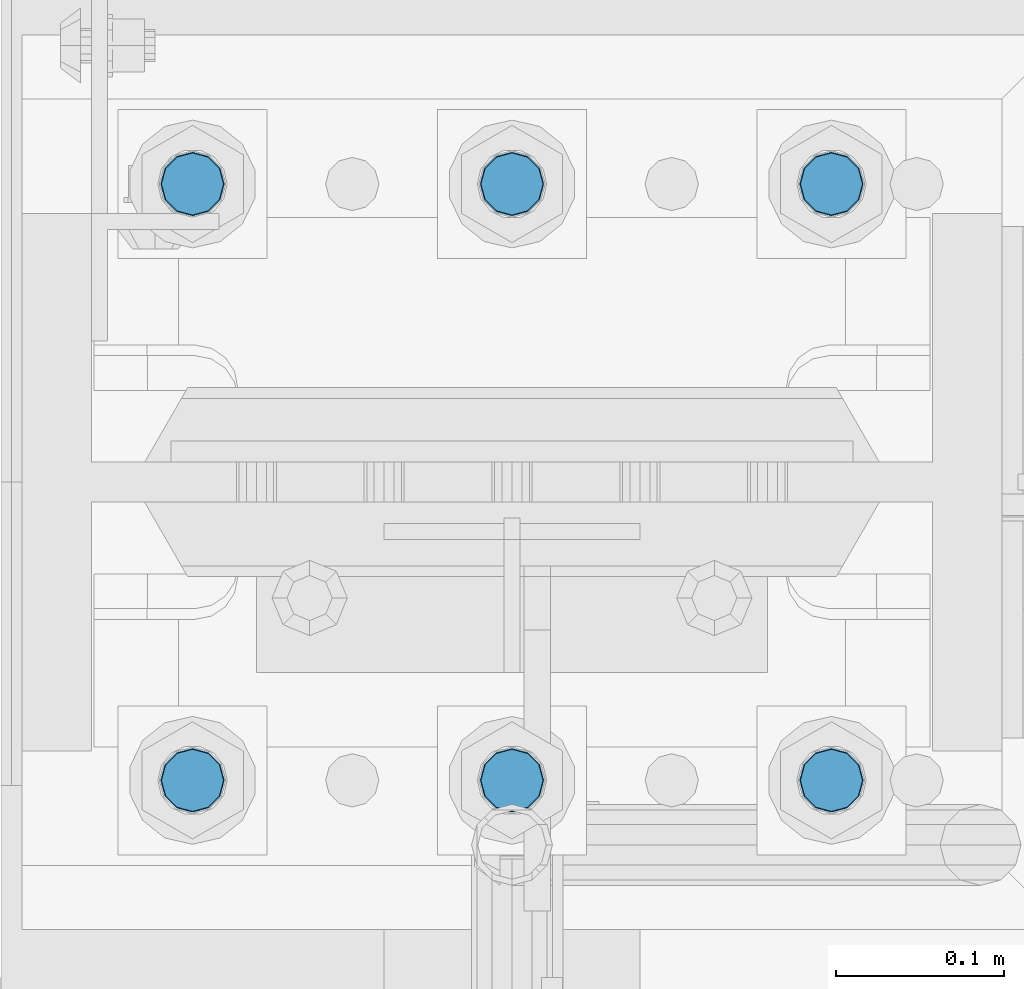
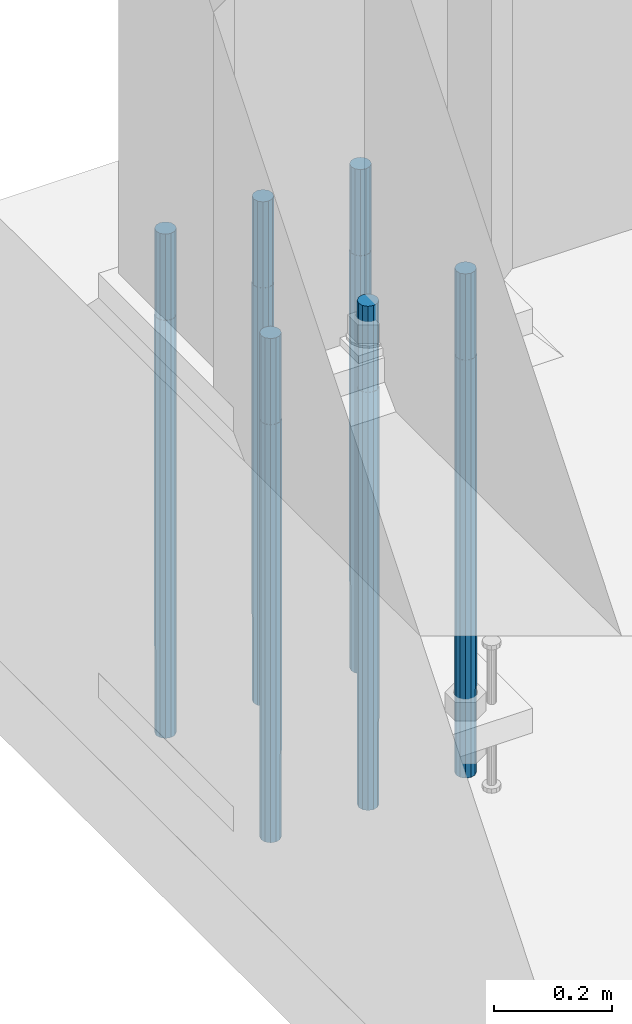
# One storey, part 750 of 1876: 6 columns, 1 element without a shape of its own.
"""IFC2X3 building model written with IfcOpenShell, lengths in millimetres."""

from ifc_helpers import new_model, si_unit, frame, origin_with_axes, place, context, subcontext, project, spatial, faceted_brep, material, type_object, element, aggregate, save


model = new_model("IFC2X3")

# Units and contexts
model_context = context("Model", 3, precision=1e-05, world=origin_with_axes())
body_context = subcontext(model_context, "Body", "Model", "MODEL_VIEW")
ifc_project = project(units=[si_unit("LENGTHUNIT", "METRE", prefix="MILLI"), si_unit("AREAUNIT", "SQUARE_METRE"), si_unit("VOLUMEUNIT", "CUBIC_METRE"), si_unit("MASSUNIT", "GRAM", prefix="KILO"), si_unit("TIMEUNIT", "SECOND"), si_unit("PLANEANGLEUNIT", "RADIAN"), si_unit("SOLIDANGLEUNIT", "STERADIAN"), si_unit("THERMODYNAMICTEMPERATUREUNIT", "DEGREE_CELSIUS"), si_unit("LUMINOUSINTENSITYUNIT", "LUMEN")], contexts=[model_context])

# Site, building, storey
site_placement = place(None, origin_with_axes())
site = spatial("IfcSite", under=ifc_project, at=site_placement, CompositionType="ELEMENT")
building_placement = place(site_placement, origin_with_axes())
building = spatial("IfcBuilding", under=site, at=building_placement, Name="Undefined", CompositionType="ELEMENT")
storey_placement = place(building_placement, origin_with_axes())
storey = spatial("IfcBuildingStorey", under=building, at=storey_placement, Name="Undefined", CompositionType="ELEMENT", Elevation=0.0)

# Assembly, columns
assembly_placement = place(storey_placement, origin_with_axes())
assembly = element("IfcElementAssembly", 1, at=assembly_placement, inside=storey, Name="TEMPLATE", AssemblyPlace="NOTDEFINED", PredefinedType="RIGID_FRAME")
ifc_material = material(Name="STEEL/F1554-GR.105")
column_type = type_object("IfcColumnType", PredefinedType="NOTDEFINED")
column_1_placement = place(assembly_placement, frame((190.5, 13538.2, 0.0), z_axis=(1.0, 0.0, 0.0), x_axis=(0.0, 0.0, -1.0)))
column_1 = element("IfcColumn", 2, at=column_1_placement, type_object=column_type, material=ifc_material, Name="ANCHOR_BOLTS", context=body_context, shape_type="Brep", body=[
    faceted_brep([(-177.8, -16.0214699700118, 9.25), (-177.8, -9.25, 16.0214699700121), (-177.8, 0.0, 18.5), (-177.8, 9.25, 16.0214699700121), (-177.8, 16.0214699700118, 9.25), (-177.8, 18.5, 0.0), (-177.8, 16.0214699700118, -9.25), (-177.8, 9.25, -16.0214699700121), (-177.8, 0.0, -18.5), (-177.8, -9.25, -16.0214699700121), (-177.8, -16.0214699700118, -9.25), (-177.8, -18.5, 0.0), (0.0, 18.5, 0.0), (0.0, 16.0214699700118, -9.25), (0.0, 9.25, -16.0214699700121), (0.0, 0.0, -18.5), (0.0, -9.25, -16.0214699700121), (0.0, -16.0214699700118, -9.25), (0.0, -18.5, 0.0), (0.0, -16.0214699700118, 9.25), (0.0, -9.25, 16.0214699700121), (0.0, 0.0, 18.5), (0.0, 9.25, 16.0214699700121), (0.0, 16.0214699700118, 9.25), (0.0, -16.4977839420935, 9.52500000000146), (0.0, -9.52500000000009, 16.4977839420935), (0.0, 0.0, 19.0499999999993), (0.0, 9.52500000000009, 16.4977839420935), (0.0, 16.4977839420935, 9.52500000000146), (-9.09494701772928e-13, 19.05, -1.81898940354586e-12), (0.0, 16.4977839420935, -9.52500000000146), (0.0, 9.52500000000009, -16.4977839420935), (0.0, 0.0, -19.05), (0.0, -9.52500000000009, -16.4977839420935), (0.0, -16.4977839420935, -9.52500000000146), (0.0, -19.0500000000002, 0.0), (685.799999999999, -19.05, 0.0), (685.799999999999, -16.4977839420936, 9.52500000000146), (685.799999999999, -9.52499999999998, 16.4977839420935), (685.799999999999, 0.0, 19.0499999999993), (685.799999999999, 9.52499999999998, 16.4977839420935), (685.799999999999, 16.4977839420936, 9.52500000000146), (685.799999999999, 19.05, 0.0), (685.799999999999, 16.4977839420936, -9.52500000000146), (685.799999999999, 9.52500000000003, -16.4977839420935), (685.799999999999, 0.0, -19.0499999999993), (685.799999999999, -9.52499999999998, -16.4977839420935), (685.799999999999, -16.4977839420936, -9.52500000000146), (685.8, -9.25, 16.0214699700121), (685.8, 0.0, 18.5), (685.8, 9.25, 16.0214699700121), (685.8, 16.0214699700118, 9.25), (685.8, 18.5, 0.0), (685.8, 16.0214699700118, -9.25), (685.8, 9.25, -16.0214699700121), (685.8, 0.0, -18.5), (685.8, -9.25, -16.0214699700121), (685.8, -16.0214699700118, -9.25), (685.8, -18.5, 0.0), (685.8, -16.0214699700118, 9.25), (863.6, -9.25, -16.0214699700121), (863.6, 0.0, -18.5), (863.6, 9.25, -16.0214699700121), (863.6, 16.0214699700118, -9.25), (863.6, 18.5, 0.0), (863.6, 16.0214699700118, 9.25), (863.6, 9.25, 16.0214699700121), (863.6, 0.0, 18.5), (863.6, -9.25, 16.0214699700121), (863.6, -16.0214699700118, 9.25), (863.6, -18.5, 0.0), (863.6, -16.0214699700118, -9.25)], [[[0, 1, 2, 3, 4, 5, 6, 7, 8, 9, 10, 11]], [[6, 5, 12, 13]], [[7, 6, 13, 14]], [[8, 7, 14, 15]], [[9, 8, 15, 16]], [[10, 9, 16, 17]], [[11, 10, 17, 18]], [[0, 11, 18, 19]], [[1, 0, 19, 20]], [[2, 1, 20, 21]], [[3, 2, 21, 22]], [[4, 3, 22, 23]], [[5, 4, 23, 12]], [[24, 25, 26, 27, 28, 29, 30, 31, 32, 33, 34, 35], [22, 21, 20, 19, 18, 17, 16, 15, 14, 13, 12, 23]], [[24, 35, 36, 37]], [[25, 24, 37, 38]], [[26, 25, 38, 39]], [[27, 26, 39, 40]], [[28, 27, 40, 41]], [[29, 28, 41, 42]], [[30, 29, 42, 43]], [[31, 30, 43, 44]], [[32, 31, 44, 45]], [[33, 32, 45, 46]], [[34, 33, 46, 47]], [[35, 34, 47, 36]], [[46, 45, 44, 43, 42, 41, 40, 39, 38, 37, 36, 47], [48, 49, 50, 51, 52, 53, 54, 55, 56, 57, 58, 59]], [[60, 61, 62, 63, 64, 65, 66, 67, 68, 69, 70, 71]], [[68, 67, 49, 48]], [[69, 68, 48, 59]], [[70, 69, 59, 58]], [[71, 70, 58, 57]], [[60, 71, 57, 56]], [[61, 60, 56, 55]], [[62, 61, 55, 54]], [[63, 62, 54, 53]], [[64, 63, 53, 52]], [[65, 64, 52, 51]], [[66, 65, 51, 50]], [[67, 66, 50, 49]]]),
])
column_2_placement = place(assembly_placement, frame((190.5, 13893.8, 0.0), z_axis=(-1.0, 0.0, 0.0), x_axis=(0.0, 0.0, -1.0)))
column_2 = element("IfcColumn", 3, at=column_2_placement, type_object=column_type, material=ifc_material, Name="ANCHOR_BOLTS", context=body_context, shape_type="Brep", body=[
    faceted_brep([(-177.8, -16.0214699700118, 9.25), (-177.8, -9.25, 16.0214699700121), (-177.8, 0.0, 18.5), (-177.8, 9.25, 16.0214699700121), (-177.8, 16.0214699700118, 9.25), (-177.8, 18.5, 0.0), (-177.8, 16.0214699700118, -9.25), (-177.8, 9.25, -16.0214699700121), (-177.8, 0.0, -18.5), (-177.8, -9.25, -16.0214699700121), (-177.8, -16.0214699700118, -9.25), (-177.8, -18.5, 0.0), (0.0, 18.5, 0.0), (0.0, 16.0214699700118, -9.25), (0.0, 9.25, -16.0214699700121), (0.0, 0.0, -18.5), (0.0, -9.25, -16.0214699700121), (0.0, -16.0214699700118, -9.25), (0.0, -18.5, 0.0), (0.0, -16.0214699700118, 9.25), (0.0, -9.25, 16.0214699700121), (0.0, 0.0, 18.5), (0.0, 9.25, 16.0214699700121), (0.0, 16.0214699700118, 9.25), (0.0, -16.4977839420935, 9.52500000000146), (0.0, -9.52500000000009, 16.4977839420935), (0.0, 0.0, 19.0499999999993), (0.0, 9.52500000000009, 16.4977839420935), (0.0, 16.4977839420935, 9.52500000000146), (-9.09494701772928e-13, 19.05, -1.81898940354586e-12), (0.0, 16.4977839420935, -9.52500000000146), (0.0, 9.52500000000009, -16.4977839420935), (0.0, 0.0, -19.05), (0.0, -9.52500000000009, -16.4977839420935), (0.0, -16.4977839420935, -9.52500000000146), (0.0, -19.0500000000002, 0.0), (685.799999999999, -19.05, 0.0), (685.799999999999, -16.4977839420936, 9.52500000000146), (685.799999999999, -9.52499999999998, 16.4977839420935), (685.799999999999, 0.0, 19.0499999999993), (685.799999999999, 9.52499999999998, 16.4977839420935), (685.799999999999, 16.4977839420936, 9.52500000000146), (685.799999999999, 19.05, 0.0), (685.799999999999, 16.4977839420936, -9.52500000000146), (685.799999999999, 9.52500000000003, -16.4977839420935), (685.799999999999, 0.0, -19.0499999999993), (685.799999999999, -9.52499999999998, -16.4977839420935), (685.799999999999, -16.4977839420936, -9.52500000000146), (685.8, -9.25, 16.0214699700121), (685.8, 0.0, 18.5), (685.8, 9.25, 16.0214699700121), (685.8, 16.0214699700118, 9.25), (685.8, 18.5, 0.0), (685.8, 16.0214699700118, -9.25), (685.8, 9.25, -16.0214699700121), (685.8, 0.0, -18.5), (685.8, -9.25, -16.0214699700121), (685.8, -16.0214699700118, -9.25), (685.8, -18.5, 0.0), (685.8, -16.0214699700118, 9.25), (863.6, -9.25, -16.0214699700121), (863.6, 0.0, -18.5), (863.6, 9.25, -16.0214699700121), (863.6, 16.0214699700118, -9.25), (863.6, 18.5, 0.0), (863.6, 16.0214699700118, 9.25), (863.6, 9.25, 16.0214699700121), (863.6, 0.0, 18.5), (863.6, -9.25, 16.0214699700121), (863.6, -16.0214699700118, 9.25), (863.6, -18.5, 0.0), (863.6, -16.0214699700118, -9.25)], [[[0, 1, 2, 3, 4, 5, 6, 7, 8, 9, 10, 11]], [[6, 5, 12, 13]], [[7, 6, 13, 14]], [[8, 7, 14, 15]], [[9, 8, 15, 16]], [[10, 9, 16, 17]], [[11, 10, 17, 18]], [[0, 11, 18, 19]], [[1, 0, 19, 20]], [[2, 1, 20, 21]], [[3, 2, 21, 22]], [[4, 3, 22, 23]], [[5, 4, 23, 12]], [[24, 25, 26, 27, 28, 29, 30, 31, 32, 33, 34, 35], [22, 21, 20, 19, 18, 17, 16, 15, 14, 13, 12, 23]], [[24, 35, 36, 37]], [[25, 24, 37, 38]], [[26, 25, 38, 39]], [[27, 26, 39, 40]], [[28, 27, 40, 41]], [[29, 28, 41, 42]], [[30, 29, 42, 43]], [[31, 30, 43, 44]], [[32, 31, 44, 45]], [[33, 32, 45, 46]], [[34, 33, 46, 47]], [[35, 34, 47, 36]], [[46, 45, 44, 43, 42, 41, 40, 39, 38, 37, 36, 47], [48, 49, 50, 51, 52, 53, 54, 55, 56, 57, 58, 59]], [[60, 61, 62, 63, 64, 65, 66, 67, 68, 69, 70, 71]], [[68, 67, 49, 48]], [[69, 68, 48, 59]], [[70, 69, 59, 58]], [[71, 70, 58, 57]], [[60, 71, 57, 56]], [[61, 60, 56, 55]], [[62, 61, 55, 54]], [[63, 62, 54, 53]], [[64, 63, 53, 52]], [[65, 64, 52, 51]], [[66, 65, 51, 50]], [[67, 66, 50, 49]]]),
])
column_3_placement = place(assembly_placement, frame((-2.8421709430404e-14, 13538.2, 0.0), z_axis=(1.0, 0.0, 0.0), x_axis=(0.0, 0.0, -1.0)))
column_3 = element("IfcColumn", 4, at=column_3_placement, type_object=column_type, material=ifc_material, Name="ANCHOR_BOLTS", context=body_context, shape_type="Brep", body=[
    faceted_brep([(-177.8, -16.0214699700118, 9.25), (-177.8, -9.25, 16.0214699700121), (-177.8, 0.0, 18.5), (-177.8, 9.25, 16.0214699700121), (-177.8, 16.0214699700118, 9.25), (-177.8, 18.5, 0.0), (-177.8, 16.0214699700118, -9.25), (-177.8, 9.25, -16.0214699700121), (-177.8, 0.0, -18.5), (-177.8, -9.25, -16.0214699700121), (-177.8, -16.0214699700118, -9.25), (-177.8, -18.5, 0.0), (0.0, 18.5, 0.0), (0.0, 16.0214699700118, -9.25), (0.0, 9.25, -16.0214699700121), (0.0, 0.0, -18.5), (0.0, -9.25, -16.0214699700121), (0.0, -16.0214699700118, -9.25), (0.0, -18.5, 0.0), (0.0, -16.0214699700118, 9.25), (0.0, -9.25, 16.0214699700121), (0.0, 0.0, 18.5), (0.0, 9.25, 16.0214699700121), (0.0, 16.0214699700118, 9.25), (0.0, -16.4977839420935, 9.52500000000146), (0.0, -9.52500000000009, 16.4977839420935), (0.0, 0.0, 19.0499999999993), (0.0, 9.52500000000009, 16.4977839420935), (0.0, 16.4977839420935, 9.52500000000146), (-9.09494701772928e-13, 19.05, -1.81898940354586e-12), (0.0, 16.4977839420935, -9.52500000000146), (0.0, 9.52500000000009, -16.4977839420935), (0.0, 0.0, -19.05), (0.0, -9.52500000000009, -16.4977839420935), (0.0, -16.4977839420935, -9.52500000000146), (0.0, -19.0500000000002, 0.0), (685.799999999999, -19.05, 0.0), (685.799999999999, -16.4977839420936, 9.52500000000146), (685.799999999999, -9.52499999999998, 16.4977839420935), (685.799999999999, 0.0, 19.0499999999993), (685.799999999999, 9.52499999999998, 16.4977839420935), (685.799999999999, 16.4977839420936, 9.52500000000146), (685.799999999999, 19.05, 0.0), (685.799999999999, 16.4977839420936, -9.52500000000146), (685.799999999999, 9.52500000000003, -16.4977839420935), (685.799999999999, 0.0, -19.0499999999993), (685.799999999999, -9.52499999999998, -16.4977839420935), (685.799999999999, -16.4977839420936, -9.52500000000146), (685.8, -9.25, 16.0214699700121), (685.8, 0.0, 18.5), (685.8, 9.25, 16.0214699700121), (685.8, 16.0214699700118, 9.25), (685.8, 18.5, 0.0), (685.8, 16.0214699700118, -9.25), (685.8, 9.25, -16.0214699700121), (685.8, 0.0, -18.5), (685.8, -9.25, -16.0214699700121), (685.8, -16.0214699700118, -9.25), (685.8, -18.5, 0.0), (685.8, -16.0214699700118, 9.25), (863.6, -9.25, -16.0214699700121), (863.6, 0.0, -18.5), (863.6, 9.25, -16.0214699700121), (863.6, 16.0214699700118, -9.25), (863.6, 18.5, 0.0), (863.6, 16.0214699700118, 9.25), (863.6, 9.25, 16.0214699700121), (863.6, 0.0, 18.5), (863.6, -9.25, 16.0214699700121), (863.6, -16.0214699700118, 9.25), (863.6, -18.5, 0.0), (863.6, -16.0214699700118, -9.25)], [[[0, 1, 2, 3, 4, 5, 6, 7, 8, 9, 10, 11]], [[6, 5, 12, 13]], [[7, 6, 13, 14]], [[8, 7, 14, 15]], [[9, 8, 15, 16]], [[10, 9, 16, 17]], [[11, 10, 17, 18]], [[0, 11, 18, 19]], [[1, 0, 19, 20]], [[2, 1, 20, 21]], [[3, 2, 21, 22]], [[4, 3, 22, 23]], [[5, 4, 23, 12]], [[24, 25, 26, 27, 28, 29, 30, 31, 32, 33, 34, 35], [22, 21, 20, 19, 18, 17, 16, 15, 14, 13, 12, 23]], [[24, 35, 36, 37]], [[25, 24, 37, 38]], [[26, 25, 38, 39]], [[27, 26, 39, 40]], [[28, 27, 40, 41]], [[29, 28, 41, 42]], [[30, 29, 42, 43]], [[31, 30, 43, 44]], [[32, 31, 44, 45]], [[33, 32, 45, 46]], [[34, 33, 46, 47]], [[35, 34, 47, 36]], [[46, 45, 44, 43, 42, 41, 40, 39, 38, 37, 36, 47], [48, 49, 50, 51, 52, 53, 54, 55, 56, 57, 58, 59]], [[60, 61, 62, 63, 64, 65, 66, 67, 68, 69, 70, 71]], [[68, 67, 49, 48]], [[69, 68, 48, 59]], [[70, 69, 59, 58]], [[71, 70, 58, 57]], [[60, 71, 57, 56]], [[61, 60, 56, 55]], [[62, 61, 55, 54]], [[63, 62, 54, 53]], [[64, 63, 53, 52]], [[65, 64, 52, 51]], [[66, 65, 51, 50]], [[67, 66, 50, 49]]]),
])
column_4_placement = place(assembly_placement, frame((-2.8421709430404e-14, 13893.8, 0.0), z_axis=(-1.0, 0.0, 0.0), x_axis=(0.0, 0.0, -1.0)))
column_4 = element("IfcColumn", 5, at=column_4_placement, type_object=column_type, material=ifc_material, Name="ANCHOR_BOLTS", context=body_context, shape_type="Brep", body=[
    faceted_brep([(-177.8, -16.0214699700118, 9.25), (-177.8, -9.25, 16.0214699700121), (-177.8, 0.0, 18.5), (-177.8, 9.25, 16.0214699700121), (-177.8, 16.0214699700118, 9.25), (-177.8, 18.5, 0.0), (-177.8, 16.0214699700118, -9.25), (-177.8, 9.25, -16.0214699700121), (-177.8, 0.0, -18.5), (-177.8, -9.25, -16.0214699700121), (-177.8, -16.0214699700118, -9.25), (-177.8, -18.5, 0.0), (0.0, 18.5, 0.0), (0.0, 16.0214699700118, -9.25), (0.0, 9.25, -16.0214699700121), (0.0, 0.0, -18.5), (0.0, -9.25, -16.0214699700121), (0.0, -16.0214699700118, -9.25), (0.0, -18.5, 0.0), (0.0, -16.0214699700118, 9.25), (0.0, -9.25, 16.0214699700121), (0.0, 0.0, 18.5), (0.0, 9.25, 16.0214699700121), (0.0, 16.0214699700118, 9.25), (0.0, -16.4977839420935, 9.52500000000146), (0.0, -9.52500000000009, 16.4977839420935), (0.0, 0.0, 19.0499999999993), (0.0, 9.52500000000009, 16.4977839420935), (0.0, 16.4977839420935, 9.52500000000146), (-9.09494701772928e-13, 19.05, -1.81898940354586e-12), (0.0, 16.4977839420935, -9.52500000000146), (0.0, 9.52500000000009, -16.4977839420935), (0.0, 0.0, -19.05), (0.0, -9.52500000000009, -16.4977839420935), (0.0, -16.4977839420935, -9.52500000000146), (0.0, -19.0500000000002, 0.0), (685.799999999999, -19.05, 0.0), (685.799999999999, -16.4977839420936, 9.52500000000146), (685.799999999999, -9.52499999999998, 16.4977839420935), (685.799999999999, 0.0, 19.0499999999993), (685.799999999999, 9.52499999999998, 16.4977839420935), (685.799999999999, 16.4977839420936, 9.52500000000146), (685.799999999999, 19.05, 0.0), (685.799999999999, 16.4977839420936, -9.52500000000146), (685.799999999999, 9.52500000000003, -16.4977839420935), (685.799999999999, 0.0, -19.0499999999993), (685.799999999999, -9.52499999999998, -16.4977839420935), (685.799999999999, -16.4977839420936, -9.52500000000146), (685.8, -9.25, 16.0214699700121), (685.8, 0.0, 18.5), (685.8, 9.25, 16.0214699700121), (685.8, 16.0214699700118, 9.25), (685.8, 18.5, 0.0), (685.8, 16.0214699700118, -9.25), (685.8, 9.25, -16.0214699700121), (685.8, 0.0, -18.5), (685.8, -9.25, -16.0214699700121), (685.8, -16.0214699700118, -9.25), (685.8, -18.5, 0.0), (685.8, -16.0214699700118, 9.25), (863.6, -9.25, -16.0214699700121), (863.6, 0.0, -18.5), (863.6, 9.25, -16.0214699700121), (863.6, 16.0214699700118, -9.25), (863.6, 18.5, 0.0), (863.6, 16.0214699700118, 9.25), (863.6, 9.25, 16.0214699700121), (863.6, 0.0, 18.5), (863.6, -9.25, 16.0214699700121), (863.6, -16.0214699700118, 9.25), (863.6, -18.5, 0.0), (863.6, -16.0214699700118, -9.25)], [[[0, 1, 2, 3, 4, 5, 6, 7, 8, 9, 10, 11]], [[6, 5, 12, 13]], [[7, 6, 13, 14]], [[8, 7, 14, 15]], [[9, 8, 15, 16]], [[10, 9, 16, 17]], [[11, 10, 17, 18]], [[0, 11, 18, 19]], [[1, 0, 19, 20]], [[2, 1, 20, 21]], [[3, 2, 21, 22]], [[4, 3, 22, 23]], [[5, 4, 23, 12]], [[24, 25, 26, 27, 28, 29, 30, 31, 32, 33, 34, 35], [22, 21, 20, 19, 18, 17, 16, 15, 14, 13, 12, 23]], [[24, 35, 36, 37]], [[25, 24, 37, 38]], [[26, 25, 38, 39]], [[27, 26, 39, 40]], [[28, 27, 40, 41]], [[29, 28, 41, 42]], [[30, 29, 42, 43]], [[31, 30, 43, 44]], [[32, 31, 44, 45]], [[33, 32, 45, 46]], [[34, 33, 46, 47]], [[35, 34, 47, 36]], [[46, 45, 44, 43, 42, 41, 40, 39, 38, 37, 36, 47], [48, 49, 50, 51, 52, 53, 54, 55, 56, 57, 58, 59]], [[60, 61, 62, 63, 64, 65, 66, 67, 68, 69, 70, 71]], [[68, 67, 49, 48]], [[69, 68, 48, 59]], [[70, 69, 59, 58]], [[71, 70, 58, 57]], [[60, 71, 57, 56]], [[61, 60, 56, 55]], [[62, 61, 55, 54]], [[63, 62, 54, 53]], [[64, 63, 53, 52]], [[65, 64, 52, 51]], [[66, 65, 51, 50]], [[67, 66, 50, 49]]]),
])
column_5_placement = place(assembly_placement, frame((-190.5, 13538.2, 0.0), z_axis=(1.0, 0.0, 0.0), x_axis=(0.0, 0.0, -1.0)))
column_5 = element("IfcColumn", 6, at=column_5_placement, type_object=column_type, material=ifc_material, Name="ANCHOR_BOLTS", context=body_context, shape_type="Brep", body=[
    faceted_brep([(-177.8, -16.0214699700118, 9.25), (-177.8, -9.25, 16.0214699700121), (-177.8, 0.0, 18.5), (-177.8, 9.25, 16.0214699700121), (-177.8, 16.0214699700118, 9.25), (-177.8, 18.5, 0.0), (-177.8, 16.0214699700118, -9.25), (-177.8, 9.25, -16.0214699700121), (-177.8, 0.0, -18.5), (-177.8, -9.25, -16.0214699700121), (-177.8, -16.0214699700118, -9.25), (-177.8, -18.5, 0.0), (0.0, 18.5, 0.0), (0.0, 16.0214699700118, -9.25), (0.0, 9.25, -16.0214699700121), (0.0, 0.0, -18.5), (0.0, -9.25, -16.0214699700121), (0.0, -16.0214699700118, -9.25), (0.0, -18.5, 0.0), (0.0, -16.0214699700118, 9.25), (0.0, -9.25, 16.0214699700121), (0.0, 0.0, 18.5), (0.0, 9.25, 16.0214699700121), (0.0, 16.0214699700118, 9.25), (0.0, -16.4977839420935, 9.52500000000146), (0.0, -9.52500000000009, 16.4977839420935), (0.0, 0.0, 19.0499999999993), (0.0, 9.52500000000009, 16.4977839420935), (0.0, 16.4977839420935, 9.52500000000146), (-9.09494701772928e-13, 19.05, -1.81898940354586e-12), (0.0, 16.4977839420935, -9.52500000000146), (0.0, 9.52500000000009, -16.4977839420935), (0.0, 0.0, -19.05), (0.0, -9.52500000000009, -16.4977839420935), (0.0, -16.4977839420935, -9.52500000000146), (0.0, -19.0500000000002, 0.0), (685.799999999999, -19.05, 0.0), (685.799999999999, -16.4977839420936, 9.52500000000146), (685.799999999999, -9.52499999999998, 16.4977839420935), (685.799999999999, 0.0, 19.0499999999993), (685.799999999999, 9.52499999999998, 16.4977839420935), (685.799999999999, 16.4977839420936, 9.52500000000146), (685.799999999999, 19.05, 0.0), (685.799999999999, 16.4977839420936, -9.52500000000146), (685.799999999999, 9.52500000000003, -16.4977839420935), (685.799999999999, 0.0, -19.0499999999993), (685.799999999999, -9.52499999999998, -16.4977839420935), (685.799999999999, -16.4977839420936, -9.52500000000146), (685.8, -9.25, 16.0214699700121), (685.8, 0.0, 18.5), (685.8, 9.25, 16.0214699700121), (685.8, 16.0214699700118, 9.25), (685.8, 18.5, 0.0), (685.8, 16.0214699700118, -9.25), (685.8, 9.25, -16.0214699700121), (685.8, 0.0, -18.5), (685.8, -9.25, -16.0214699700121), (685.8, -16.0214699700118, -9.25), (685.8, -18.5, 0.0), (685.8, -16.0214699700118, 9.25), (863.6, -9.25, -16.0214699700121), (863.6, 0.0, -18.5), (863.6, 9.25, -16.0214699700121), (863.6, 16.0214699700118, -9.25), (863.6, 18.5, 0.0), (863.6, 16.0214699700118, 9.25), (863.6, 9.25, 16.0214699700121), (863.6, 0.0, 18.5), (863.6, -9.25, 16.0214699700121), (863.6, -16.0214699700118, 9.25), (863.6, -18.5, 0.0), (863.6, -16.0214699700118, -9.25)], [[[0, 1, 2, 3, 4, 5, 6, 7, 8, 9, 10, 11]], [[6, 5, 12, 13]], [[7, 6, 13, 14]], [[8, 7, 14, 15]], [[9, 8, 15, 16]], [[10, 9, 16, 17]], [[11, 10, 17, 18]], [[0, 11, 18, 19]], [[1, 0, 19, 20]], [[2, 1, 20, 21]], [[3, 2, 21, 22]], [[4, 3, 22, 23]], [[5, 4, 23, 12]], [[24, 25, 26, 27, 28, 29, 30, 31, 32, 33, 34, 35], [22, 21, 20, 19, 18, 17, 16, 15, 14, 13, 12, 23]], [[24, 35, 36, 37]], [[25, 24, 37, 38]], [[26, 25, 38, 39]], [[27, 26, 39, 40]], [[28, 27, 40, 41]], [[29, 28, 41, 42]], [[30, 29, 42, 43]], [[31, 30, 43, 44]], [[32, 31, 44, 45]], [[33, 32, 45, 46]], [[34, 33, 46, 47]], [[35, 34, 47, 36]], [[46, 45, 44, 43, 42, 41, 40, 39, 38, 37, 36, 47], [48, 49, 50, 51, 52, 53, 54, 55, 56, 57, 58, 59]], [[60, 61, 62, 63, 64, 65, 66, 67, 68, 69, 70, 71]], [[68, 67, 49, 48]], [[69, 68, 48, 59]], [[70, 69, 59, 58]], [[71, 70, 58, 57]], [[60, 71, 57, 56]], [[61, 60, 56, 55]], [[62, 61, 55, 54]], [[63, 62, 54, 53]], [[64, 63, 53, 52]], [[65, 64, 52, 51]], [[66, 65, 51, 50]], [[67, 66, 50, 49]]]),
])
column_6_placement = place(assembly_placement, frame((-190.5, 13893.8, 0.0), z_axis=(-1.0, 0.0, 0.0), x_axis=(0.0, 0.0, -1.0)))
column_6 = element("IfcColumn", 7, at=column_6_placement, type_object=column_type, material=ifc_material, Name="ANCHOR_BOLTS", context=body_context, shape_type="Brep", body=[
    faceted_brep([(-177.8, -16.0214699700118, 9.25), (-177.8, -9.25, 16.0214699700121), (-177.8, 0.0, 18.5), (-177.8, 9.25, 16.0214699700121), (-177.8, 16.0214699700118, 9.25), (-177.8, 18.5, 0.0), (-177.8, 16.0214699700118, -9.25), (-177.8, 9.25, -16.0214699700121), (-177.8, 0.0, -18.5), (-177.8, -9.25, -16.0214699700121), (-177.8, -16.0214699700118, -9.25), (-177.8, -18.5, 0.0), (0.0, 18.5, 0.0), (0.0, 16.0214699700118, -9.25), (0.0, 9.25, -16.0214699700121), (0.0, 0.0, -18.5), (0.0, -9.25, -16.0214699700121), (0.0, -16.0214699700118, -9.25), (0.0, -18.5, 0.0), (0.0, -16.0214699700118, 9.25), (0.0, -9.25, 16.0214699700121), (0.0, 0.0, 18.5), (0.0, 9.25, 16.0214699700121), (0.0, 16.0214699700118, 9.25), (0.0, -16.4977839420935, 9.52500000000146), (0.0, -9.52500000000009, 16.4977839420935), (0.0, 0.0, 19.0499999999993), (0.0, 9.52500000000009, 16.4977839420935), (0.0, 16.4977839420935, 9.52500000000146), (-9.09494701772928e-13, 19.05, -1.81898940354586e-12), (0.0, 16.4977839420935, -9.52500000000146), (0.0, 9.52500000000009, -16.4977839420935), (0.0, 0.0, -19.05), (0.0, -9.52500000000009, -16.4977839420935), (0.0, -16.4977839420935, -9.52500000000146), (0.0, -19.0500000000002, 0.0), (685.799999999999, -19.05, 0.0), (685.799999999999, -16.4977839420936, 9.52500000000146), (685.799999999999, -9.52499999999998, 16.4977839420935), (685.799999999999, 0.0, 19.0499999999993), (685.799999999999, 9.52499999999998, 16.4977839420935), (685.799999999999, 16.4977839420936, 9.52500000000146), (685.799999999999, 19.05, 0.0), (685.799999999999, 16.4977839420936, -9.52500000000146), (685.799999999999, 9.52500000000003, -16.4977839420935), (685.799999999999, 0.0, -19.0499999999993), (685.799999999999, -9.52499999999998, -16.4977839420935), (685.799999999999, -16.4977839420936, -9.52500000000146), (685.8, -9.25, 16.0214699700121), (685.8, 0.0, 18.5), (685.8, 9.25, 16.0214699700121), (685.8, 16.0214699700118, 9.25), (685.8, 18.5, 0.0), (685.8, 16.0214699700118, -9.25), (685.8, 9.25, -16.0214699700121), (685.8, 0.0, -18.5), (685.8, -9.25, -16.0214699700121), (685.8, -16.0214699700118, -9.25), (685.8, -18.5, 0.0), (685.8, -16.0214699700118, 9.25), (863.6, -9.25, -16.0214699700121), (863.6, 0.0, -18.5), (863.6, 9.25, -16.0214699700121), (863.6, 16.0214699700118, -9.25), (863.6, 18.5, 0.0), (863.6, 16.0214699700118, 9.25), (863.6, 9.25, 16.0214699700121), (863.6, 0.0, 18.5), (863.6, -9.25, 16.0214699700121), (863.6, -16.0214699700118, 9.25), (863.6, -18.5, 0.0), (863.6, -16.0214699700118, -9.25)], [[[0, 1, 2, 3, 4, 5, 6, 7, 8, 9, 10, 11]], [[6, 5, 12, 13]], [[7, 6, 13, 14]], [[8, 7, 14, 15]], [[9, 8, 15, 16]], [[10, 9, 16, 17]], [[11, 10, 17, 18]], [[0, 11, 18, 19]], [[1, 0, 19, 20]], [[2, 1, 20, 21]], [[3, 2, 21, 22]], [[4, 3, 22, 23]], [[5, 4, 23, 12]], [[24, 25, 26, 27, 28, 29, 30, 31, 32, 33, 34, 35], [22, 21, 20, 19, 18, 17, 16, 15, 14, 13, 12, 23]], [[24, 35, 36, 37]], [[25, 24, 37, 38]], [[26, 25, 38, 39]], [[27, 26, 39, 40]], [[28, 27, 40, 41]], [[29, 28, 41, 42]], [[30, 29, 42, 43]], [[31, 30, 43, 44]], [[32, 31, 44, 45]], [[33, 32, 45, 46]], [[34, 33, 46, 47]], [[35, 34, 47, 36]], [[46, 45, 44, 43, 42, 41, 40, 39, 38, 37, 36, 47], [48, 49, 50, 51, 52, 53, 54, 55, 56, 57, 58, 59]], [[60, 61, 62, 63, 64, 65, 66, 67, 68, 69, 70, 71]], [[68, 67, 49, 48]], [[69, 68, 48, 59]], [[70, 69, 59, 58]], [[71, 70, 58, 57]], [[60, 71, 57, 56]], [[61, 60, 56, 55]], [[62, 61, 55, 54]], [[63, 62, 54, 53]], [[64, 63, 53, 52]], [[65, 64, 52, 51]], [[66, 65, 51, 50]], [[67, 66, 50, 49]]]),
])
aggregate(assembly, [column_1, column_2, column_3, column_4, column_5, column_6])

save(model, "model.ifc")
